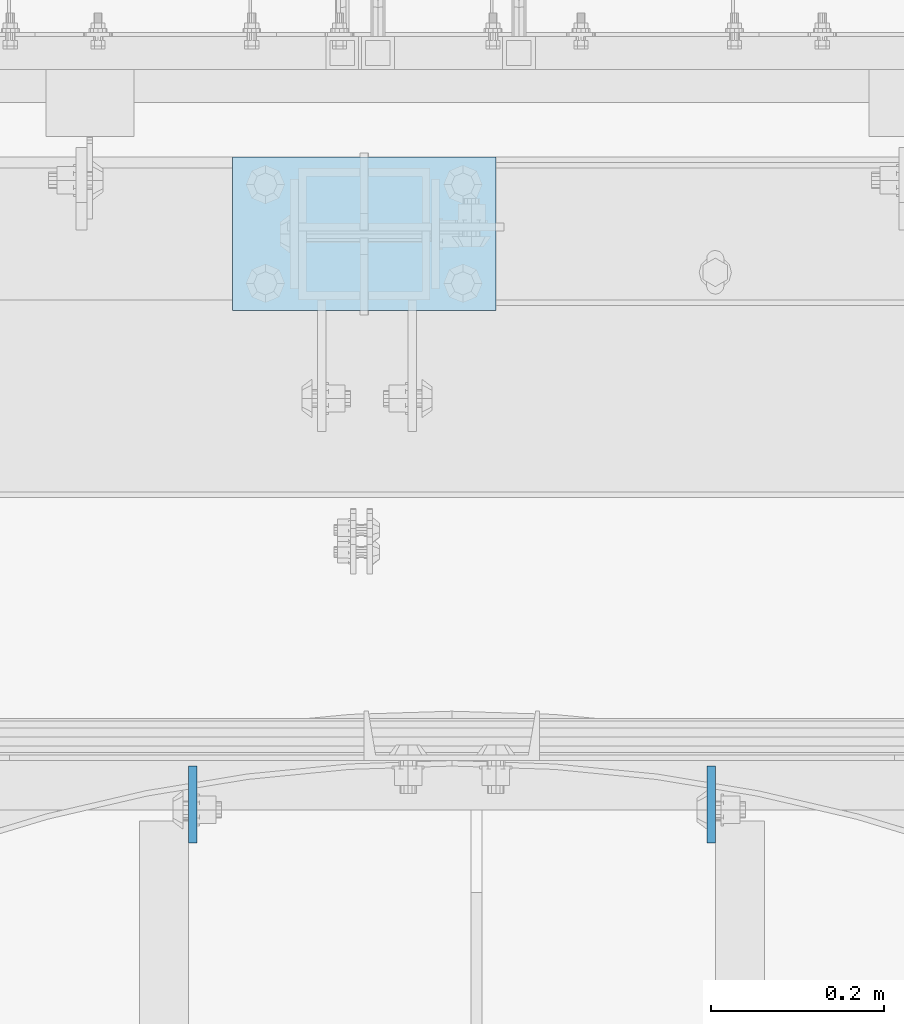
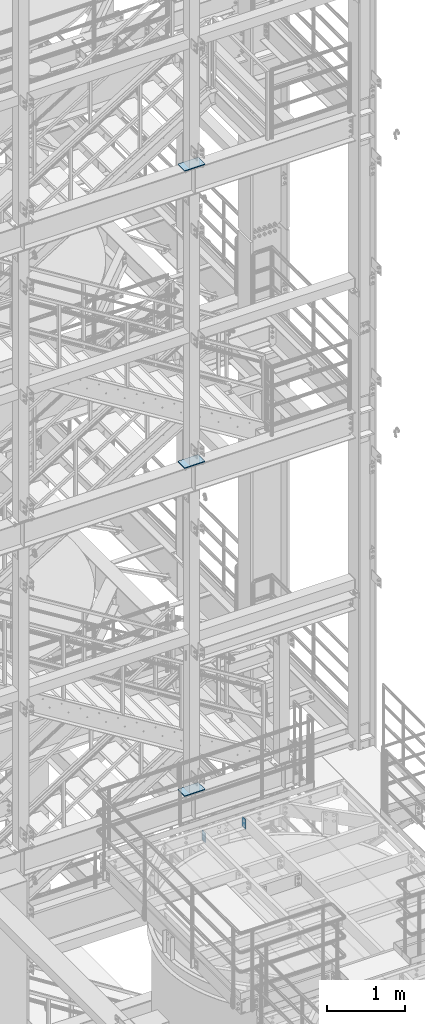
# One storey, part 1446 of 1876: 5 plates, 4 elements without a shape of their own.
"""IFC2X3 building model written with IfcOpenShell, lengths in millimetres."""

from ifc_helpers import new_model, si_unit, frame, origin_with_axes, place, context, subcontext, project, spatial, faceted_brep, material, type_object, element, aggregate, save


model = new_model("IFC2X3")

# Units and contexts
model_context = context("Model", 3, precision=1e-05, world=origin_with_axes())
body_context = subcontext(model_context, "Body", "Model", "MODEL_VIEW")
ifc_project = project(units=[si_unit("LENGTHUNIT", "METRE", prefix="MILLI"), si_unit("AREAUNIT", "SQUARE_METRE"), si_unit("VOLUMEUNIT", "CUBIC_METRE"), si_unit("MASSUNIT", "GRAM", prefix="KILO"), si_unit("TIMEUNIT", "SECOND"), si_unit("PLANEANGLEUNIT", "RADIAN"), si_unit("SOLIDANGLEUNIT", "STERADIAN"), si_unit("THERMODYNAMICTEMPERATUREUNIT", "DEGREE_CELSIUS"), si_unit("LUMINOUSINTENSITYUNIT", "LUMEN")], contexts=[model_context])

# Site, building, storey
site_placement = place(None, origin_with_axes())
site = spatial("IfcSite", under=ifc_project, at=site_placement, CompositionType="ELEMENT")
building_placement = place(site_placement, origin_with_axes())
building = spatial("IfcBuilding", under=site, at=building_placement, Name="Undefined", CompositionType="ELEMENT")
storey_placement = place(building_placement, origin_with_axes())
storey = spatial("IfcBuildingStorey", under=building, at=storey_placement, Name="Undefined", CompositionType="ELEMENT", Elevation=0.0)

# Assembly, plate
assembly_1_placement = place(storey_placement, origin_with_axes())
assembly_1 = element("IfcElementAssembly", 1, at=assembly_1_placement, inside=storey, Name="FRAME", AssemblyPlace="NOTDEFINED", PredefinedType="RIGID_FRAME")
ifc_material = material(Name="STEEL/A36")
plate_type_1 = type_object("IfcPlateType", PredefinedType="NOTDEFINED")
plate_1_placement = place(assembly_1_placement, frame((5232.4, -7200.9, 17989.55), z_axis=(-1.0, 0.0, 0.0), x_axis=(0.0, 1.0, 0.0)))
plate_1 = element("IfcPlate", 2, at=plate_1_placement, type_object=plate_type_1, material=ifc_material, Name="PLATE", context=body_context, shape_type="Brep", body=[
    faceted_brep([(0.0, -6.35000000000036, 0.0), (0.0, -6.35000000000036, 304.799987792969), (0.0, 6.35000000000036, 304.799987792969), (0.0, 6.35000000000036, 0.0), (177.800003051758, -6.35000000000036, 304.799987792969), (177.800003051758, 6.35000000000036, 304.799987792969), (177.800003051758, -6.35000000000036, 0.0), (177.800003051758, 6.35000000000036, 0.0)], [[[0, 1, 2, 3]], [[1, 4, 5, 2]], [[4, 6, 7, 5]], [[6, 0, 3, 7]], [[5, 7, 3, 2]], [[6, 4, 1, 0]]]),
])
aggregate(assembly_1, [plate_1])

assembly_2_placement = place(storey_placement, origin_with_axes())
assembly_2 = element("IfcElementAssembly", 3, at=assembly_2_placement, inside=storey, Name="FRAME", AssemblyPlace="NOTDEFINED", PredefinedType="RIGID_FRAME")
plate_2_placement = place(assembly_2_placement, frame((5232.4, -7200.9, 13315.95), z_axis=(-1.0, 0.0, 0.0), x_axis=(0.0, 1.0, 0.0)))
plate_2 = element("IfcPlate", 4, at=plate_2_placement, type_object=plate_type_1, material=ifc_material, Name="PLATE", context=body_context, shape_type="Brep", body=[
    faceted_brep([(0.0, -6.35000000000036, 0.0), (0.0, -6.35000000000036, 304.799987792969), (0.0, 6.35000000000036, 304.799987792969), (0.0, 6.35000000000036, 0.0), (177.800003051758, -6.35000000000036, 304.799987792969), (177.800003051758, 6.35000000000036, 304.799987792969), (177.800003051758, -6.35000000000036, 0.0), (177.800003051758, 6.35000000000036, 0.0)], [[[0, 1, 2, 3]], [[1, 4, 5, 2]], [[4, 6, 7, 5]], [[6, 0, 3, 7]], [[5, 7, 3, 2]], [[6, 4, 1, 0]]]),
])
aggregate(assembly_2, [plate_2])

assembly_3_placement = place(storey_placement, origin_with_axes())
assembly_3 = element("IfcElementAssembly", 5, at=assembly_3_placement, inside=storey, Name="FRAME", AssemblyPlace="NOTDEFINED", PredefinedType="RIGID_FRAME")
plate_3_placement = place(assembly_3_placement, frame((5232.4, -7200.9, 8159.75), z_axis=(-1.0, 0.0, 0.0), x_axis=(0.0, 1.0, 0.0)))
plate_3 = element("IfcPlate", 6, at=plate_3_placement, type_object=plate_type_1, material=ifc_material, Name="PLATE", context=body_context, shape_type="Brep", body=[
    faceted_brep([(0.0, -6.35000000000036, 0.0), (0.0, -6.35000000000036, 304.799987792969), (0.0, 6.35000000000036, 304.799987792969), (0.0, 6.35000000000036, 0.0), (177.800003051758, -6.35000000000036, 304.799987792969), (177.800003051758, 6.35000000000036, 304.799987792969), (177.800003051758, -6.35000000000036, 0.0), (177.800003051758, 6.35000000000036, 0.0)], [[[0, 1, 2, 3]], [[1, 4, 5, 2]], [[4, 6, 7, 5]], [[6, 0, 3, 7]], [[5, 7, 3, 2]], [[6, 4, 1, 0]]]),
])
aggregate(assembly_3, [plate_3])

# Assembly, plates
assembly_4_placement = place(storey_placement, origin_with_axes())
assembly_4 = element("IfcElementAssembly", 7, at=assembly_4_placement, inside=storey, Name="BEAM", AssemblyPlace="NOTDEFINED", PredefinedType="RIGID_FRAME")
plate_type_2 = type_object("IfcPlateType", PredefinedType="NOTDEFINED")
plate_4_placement = place(assembly_4_placement, frame((4881.56583884985, -7727.91440429563, 7972.425), z_axis=(0.0, -1.0, 0.0), x_axis=(0.0, 0.0, -1.0)))
plate_4 = element("IfcPlate", 8, at=plate_4_placement, type_object=plate_type_2, material=ifc_material, Name="PLATE", context=body_context, shape_type="Brep", body=[
    faceted_brep([(0.0, -4.76249999999982, 0.0), (0.0, -4.76249999999982, 88.9000015258789), (0.0, 4.76249999999982, 88.9000015258789), (0.0, 4.76249999999982, 0.0), (152.399993896484, -4.76249999999982, 88.9000015258789), (152.399993896484, 4.76249999999982, 88.9000015258789), (152.399993896484, -4.76249999999982, 0.0), (152.399993896484, 4.76249999999982, 0.0)], [[[0, 1, 2, 3]], [[1, 4, 5, 2]], [[4, 6, 7, 5]], [[6, 0, 3, 7]], [[5, 7, 3, 2]], [[6, 4, 1, 0]]]),
])
plate_5_placement = place(assembly_4_placement, frame((5481.64083884985, -7727.91440429563, 7972.425), z_axis=(0.0, -1.0, 0.0), x_axis=(0.0, 0.0, -1.0)))
plate_5 = element("IfcPlate", 9, at=plate_5_placement, type_object=plate_type_2, material=ifc_material, Name="PLATE", context=body_context, shape_type="Brep", body=[
    faceted_brep([(0.0, -4.76249999999982, 0.0), (0.0, -4.76249999999982, 88.9000015258789), (0.0, 4.76249999999982, 88.9000015258789), (0.0, 4.76249999999982, 0.0), (152.399993896484, -4.76249999999982, 88.9000015258789), (152.399993896484, 4.76249999999982, 88.9000015258789), (152.399993896484, -4.76249999999982, 0.0), (152.399993896484, 4.76249999999982, 0.0)], [[[0, 1, 2, 3]], [[1, 4, 5, 2]], [[4, 6, 7, 5]], [[6, 0, 3, 7]], [[5, 7, 3, 2]], [[6, 4, 1, 0]]]),
])
aggregate(assembly_4, [plate_4, plate_5])

save(model, "model.ifc")
